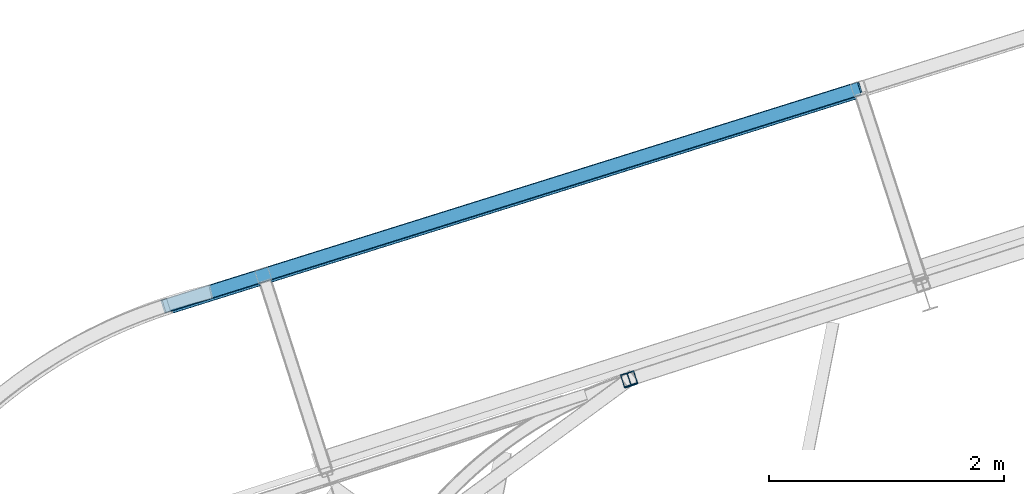
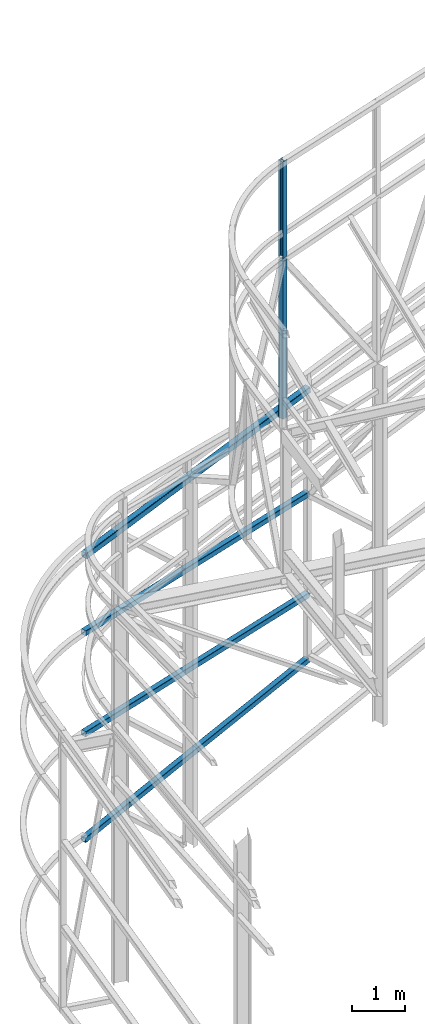
# One storey, part 80 of 215: 6 beams, 6 elements without a shape of their own.
"""IFC2X3 building model written with IfcOpenShell, lengths in millimetres."""

from ifc_helpers import new_model, si_unit, frame, origin_with_axes, origin_2d_with_axis, place, context, subcontext, project, spatial, hollow_rectangle, i_section, extrude, material, type_object, element, aggregate, save


model = new_model("IFC2X3")

# Units and contexts
model_context = context("Model", 3, precision=1e-05, world=origin_with_axes())
body_context = subcontext(model_context, "Body", "Model", "MODEL_VIEW")
ifc_project = project(units=[si_unit("LENGTHUNIT", "METRE", prefix="MILLI"), si_unit("AREAUNIT", "SQUARE_METRE"), si_unit("VOLUMEUNIT", "CUBIC_METRE"), si_unit("MASSUNIT", "GRAM", prefix="KILO"), si_unit("TIMEUNIT", "SECOND"), si_unit("PLANEANGLEUNIT", "RADIAN"), si_unit("SOLIDANGLEUNIT", "STERADIAN"), si_unit("THERMODYNAMICTEMPERATUREUNIT", "DEGREE_CELSIUS"), si_unit("LUMINOUSINTENSITYUNIT", "LUMEN")], contexts=[model_context])

# Site, building, storey
site_placement = place(None, origin_with_axes())
site = spatial("IfcSite", under=ifc_project, at=site_placement, CompositionType="ELEMENT")
building_placement = place(site_placement, origin_with_axes())
building = spatial("IfcBuilding", under=site, at=building_placement, Name="Undefined", CompositionType="ELEMENT")
storey_placement = place(building_placement, origin_with_axes())
storey = spatial("IfcBuildingStorey", under=building, at=storey_placement, Name="Undefined", CompositionType="ELEMENT", Elevation=0.0)

# Assembly, beam
assembly_1_placement = place(storey_placement, origin_with_axes())
assembly_1 = element("IfcElementAssembly", 1, at=assembly_1_placement, inside=storey, Name="Steel Assembly", AssemblyPlace="NOTDEFINED", PredefinedType="RIGID_FRAME")
ifc_material_1 = material(Name="STEEL/S235JR")
beam_type_1 = type_object("IfcBeamType", PredefinedType="NOTDEFINED")
beam_1_placement = place(assembly_1_placement, frame((47040.214168236, 61001.711581894, 2088.86955920514), z_axis=(-0.29894498301003, 0.95427034803201, 0.0), x_axis=(-0.95427034803201, -0.298944983010028, 0.0)))
beam_1 = element("IfcBeam", 2, at=beam_1_placement, type_object=beam_type_1, material=ifc_material_1, Name="LISSE", context=body_context, shape_type="SweptSolid", body=[
    extrude(hollow_rectangle(XDim=120.0, YDim=120.0, WallThickness=5.0, InnerFilletRadius=5.0, OuterFilletRadius=10.0, at=origin_2d_with_axis()), frame((6199.14271736774, 0.0, -3.44121548887951e-13), z_axis=(-1.0, 0.0, 0.0), x_axis=(-6.93889390390723e-18, -1.0, -3.46944695195361e-18)), (0.0, 0.0, 1.0), 6199.1),
])
aggregate(assembly_1, [beam_1])

assembly_2_placement = place(storey_placement, origin_with_axes())
assembly_2 = element("IfcElementAssembly", 3, at=assembly_2_placement, inside=storey, Name="Steel Assembly", AssemblyPlace="NOTDEFINED", PredefinedType="RIGID_FRAME")
beam_2_placement = place(assembly_2_placement, frame((47040.2141689128, 61001.7115819675, 4401.39704244407), z_axis=(-0.29894498301003, 0.95427034803201, 0.0), x_axis=(-0.95427034803201, -0.298944983010028, 0.0)))
beam_2 = element("IfcBeam", 4, at=beam_2_placement, type_object=beam_type_1, material=ifc_material_1, Name="LISSE", context=body_context, shape_type="SweptSolid", body=[
    extrude(hollow_rectangle(XDim=120.0, YDim=120.0, WallThickness=5.0, InnerFilletRadius=5.0, OuterFilletRadius=10.0, at=origin_2d_with_axis()), frame((6199.14226989102, 0.0, 3.44121524048003e-13), z_axis=(-1.0, 0.0, 0.0), x_axis=(-6.93889390390723e-18, -1.0, -3.46944695195361e-18)), (0.0, 0.0, 1.0), 6199.1),
])
aggregate(assembly_2, [beam_2])

assembly_3_placement = place(storey_placement, origin_with_axes())
assembly_3 = element("IfcElementAssembly", 5, at=assembly_3_placement, inside=storey, Name="Steel Assembly", AssemblyPlace="NOTDEFINED", PredefinedType="RIGID_FRAME")
ifc_material_2 = material(Name="STEEL/S275JR")
beam_3_placement = place(assembly_3_placement, frame((41120.2862717246, 59147.171358464, -335.000340237699), z_axis=(-0.29894498301003, 0.95427034803201, 0.0), x_axis=(0.943619368410225, 0.295608343128511, 0.148990587064771)))
beam_3 = element("IfcBeam", 6, at=beam_3_placement, type_object=beam_type_1, material=ifc_material_2, Name="LISSE", context=body_context, shape_type="SweptSolid", body=[
    extrude(hollow_rectangle(XDim=120.0, YDim=120.0, WallThickness=5.0, InnerFilletRadius=5.0, OuterFilletRadius=10.0, at=origin_2d_with_axis()), frame((6264.5993232872, -1.81898940354586e-12, 7.38961818661922e-12), z_axis=(-1.0, 0.0, 0.0), x_axis=(-6.93889390390723e-18, -1.0, -3.46944695195361e-18)), (0.0, 0.0, 1.0), 6264.6),
])
aggregate(assembly_3, [beam_3])

assembly_4_placement = place(storey_placement, origin_with_axes())
assembly_4 = element("IfcElementAssembly", 7, at=assembly_4_placement, inside=storey, Name="Steel Assembly", AssemblyPlace="NOTDEFINED", PredefinedType="RIGID_FRAME")
beam_4_placement = place(assembly_4_placement, frame((45082.3834893184, 58525.5704850202, 11943.8123838444), z_axis=(0.308275434998926, -0.951297143996671, -1.00000033853226e-09), x_axis=(0.0, 0.0, -1.0)))
beam_4 = element("IfcBeam", 8, at=beam_4_placement, type_object=beam_type_1, material=ifc_material_2, Name="LISSE", context=body_context, shape_type="SweptSolid", body=[
    extrude(hollow_rectangle(XDim=120.0, YDim=120.0, WallThickness=5.0, InnerFilletRadius=5.0, OuterFilletRadius=10.0, at=origin_2d_with_axis()), frame((3612.68475337076, 0.0, 0.0), z_axis=(-1.0, 0.0, 0.0), x_axis=(-6.93889390390723e-18, -1.0, -3.46944695195361e-18)), (0.0, 0.0, 1.0), 3612.7),
])
aggregate(assembly_4, [beam_4])

assembly_5_placement = place(storey_placement, origin_with_axes())
assembly_5 = element("IfcElementAssembly", 9, at=assembly_5_placement, inside=storey, Name="Steel Assembly", AssemblyPlace="NOTDEFINED", PredefinedType="RIGID_FRAME")
beam_type_2 = type_object("IfcBeamType", PredefinedType="NOTDEFINED")
beam_5_placement = place(assembly_5_placement, frame((47049.8503252433, 60994.2510969522, 6794.99928092989), z_axis=(-0.29894498301003, 0.95427034803201, 0.0), x_axis=(-0.949534536568181, -0.297461391864723, -0.0995031869547489)))
beam_5 = element("IfcBeam", 10, at=beam_5_placement, type_object=beam_type_2, material=ifc_material_1, Name="LISSE", context=body_context, shape_type="SweptSolid", body=[
    extrude(hollow_rectangle(XDim=140.0, YDim=140.0, WallThickness=8.0, InnerFilletRadius=12.0, OuterFilletRadius=20.0, at=origin_2d_with_axis()), frame((6228.06554018167, 1.75981269722787e-12, 7.75255119264057e-12), z_axis=(-1.0, 0.0, 0.0), x_axis=(-6.93889390390723e-18, -1.0, -3.46944695195361e-18)), (0.0, 0.0, 1.0), 6228.1),
])
aggregate(assembly_5, [beam_5])

assembly_6_placement = place(storey_placement, origin_with_axes())
assembly_6 = element("IfcElementAssembly", 11, at=assembly_6_placement, inside=storey, Name="Steel Assembly", AssemblyPlace="NOTDEFINED", PredefinedType="RIGID_FRAME")
beam_type_3 = type_object("IfcBeamType", Name="HEA120", PredefinedType="NOTDEFINED")
beam_6_placement = place(assembly_6_placement, frame((45081.4586535772, 58528.4243152033, 14219.9969924048), z_axis=(0.308275434998926, -0.951297143996671, -1.00000033853226e-09), x_axis=(0.0, 0.0, -1.0)))
beam_6 = element("IfcBeam", 12, at=beam_6_placement, type_object=beam_type_3, material=ifc_material_2, ObjectType="HEA120", context=body_context, shape_type="SweptSolid", body=[
    extrude(i_section(OverallWidth=120.0, OverallDepth=114.0, WebThickness=5.0, FlangeThickness=8.0, FilletRadius=12.0, at=origin_2d_with_axis()), frame((2213.78259345524, 7.27595762150822e-12, 5.49359412514062e-21), z_axis=(-1.0, 0.0, 0.0), x_axis=(-6.93889390390723e-18, -1.0, -3.46944695195361e-18)), (0.0, 0.0, 1.0), 2213.8),
])
aggregate(assembly_6, [beam_6])

save(model, "model.ifc")
